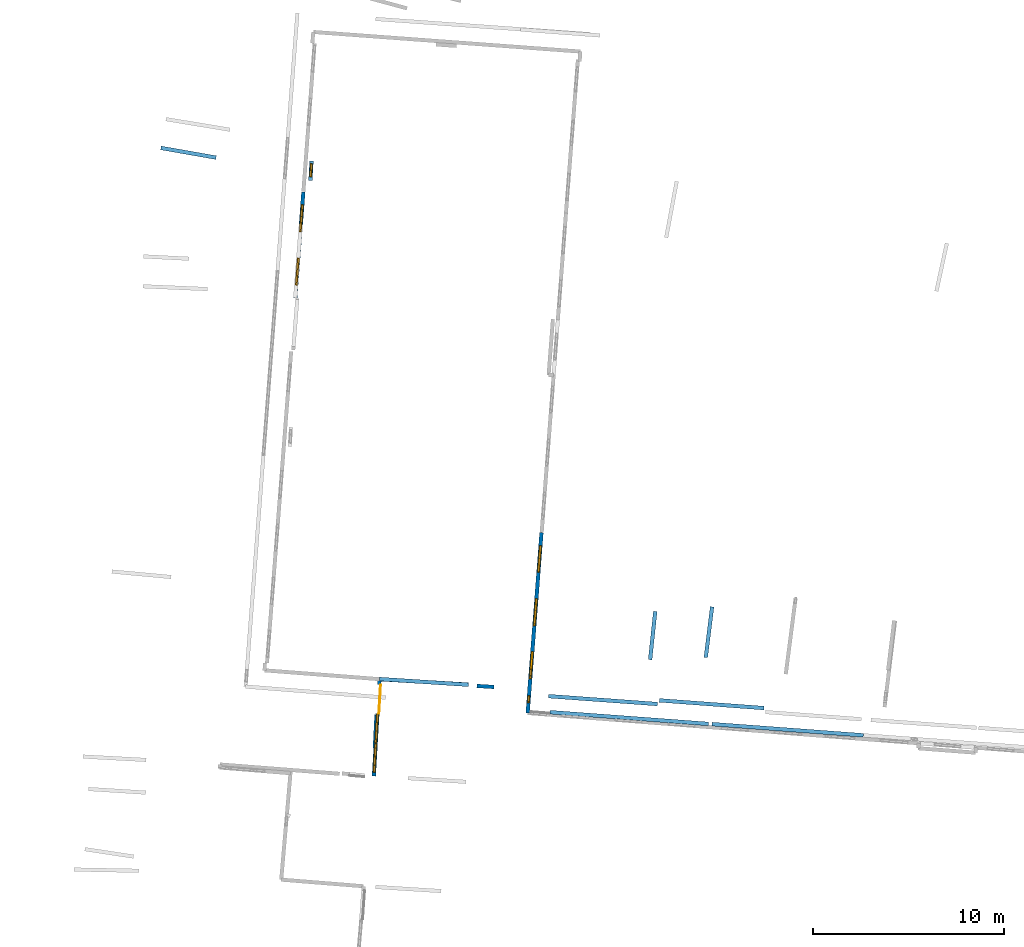
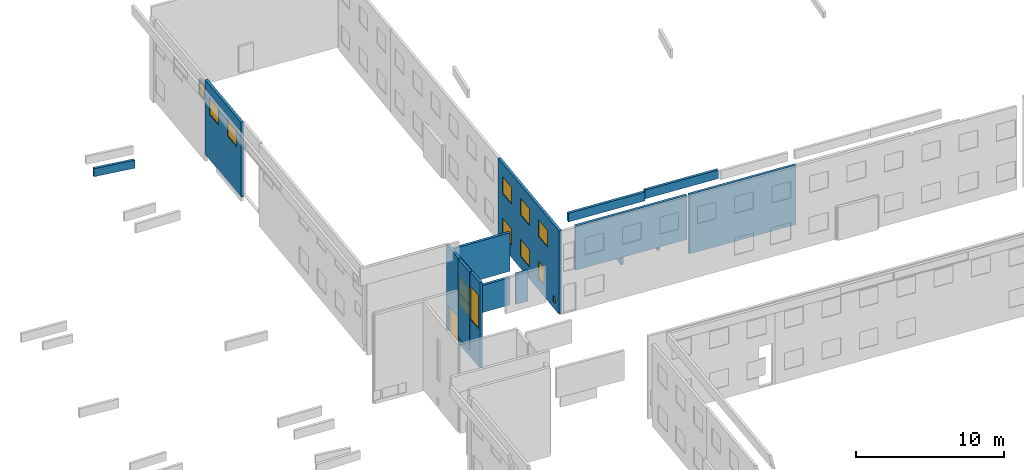
# One storey, part 10 of 27: 15 walls, 13 windows, 1 door, 14 openings.
"""IFC2X3 building model written with IfcOpenShell, lengths in metres."""

from ifc_helpers import new_model, entity, si_unit, converted_unit, derived_unit, direction, frame, frame_2d, origin, origin_2d_with_axis, place, context, subcontext, project, spatial, polyline, rectangle, outline, extrude, source, transform, mapped, material, layer, layer_set, layer_usage, type_object, type_shapes, element, fill, save


model = new_model("IFC2X3")

# Units and contexts
model_context = context("Model", 3, precision=1e-05, world=origin(), true_north=direction((0.0, 1.0)))
body_context = subcontext(model_context, "Body", "Model", "MODEL_VIEW")
ifc_project = project(units=[si_unit("LENGTHUNIT", "METRE"), si_unit("AREAUNIT", "SQUARE_METRE"), si_unit("VOLUMEUNIT", "CUBIC_METRE"), converted_unit("PLANEANGLEUNIT", "DEGREE", entity("IfcRatioMeasure", 0.0174532925199433), si_unit("PLANEANGLEUNIT", "RADIAN"), dimensions=[0, 0, 0, 0, 0, 0, 0]), si_unit("MASSUNIT", "GRAM", prefix="KILO"), derived_unit("MASSDENSITYUNIT", [(si_unit("MASSUNIT", "GRAM", prefix="KILO"), 1), (si_unit("LENGTHUNIT", "METRE"), -3)]), derived_unit("MOMENTOFINERTIAUNIT", [(si_unit("LENGTHUNIT", "METRE"), 4)]), si_unit("TIMEUNIT", "SECOND"), si_unit("FREQUENCYUNIT", "HERTZ"), si_unit("THERMODYNAMICTEMPERATUREUNIT", "DEGREE_CELSIUS"), derived_unit("THERMALTRANSMITTANCEUNIT", [(si_unit("MASSUNIT", "GRAM", prefix="KILO"), 1), (si_unit("THERMODYNAMICTEMPERATUREUNIT", "KELVIN"), -1), (si_unit("TIMEUNIT", "SECOND"), -3)]), derived_unit("VOLUMETRICFLOWRATEUNIT", [(si_unit("LENGTHUNIT", "METRE"), 3), (si_unit("TIMEUNIT", "SECOND"), -1)]), si_unit("ELECTRICCURRENTUNIT", "AMPERE"), si_unit("ELECTRICVOLTAGEUNIT", "VOLT"), si_unit("POWERUNIT", "WATT"), si_unit("FORCEUNIT", "NEWTON", prefix="KILO"), si_unit("ILLUMINANCEUNIT", "LUX"), si_unit("LUMINOUSFLUXUNIT", "LUMEN"), si_unit("LUMINOUSINTENSITYUNIT", "CANDELA"), derived_unit("USERDEFINED", [(si_unit("MASSUNIT", "GRAM", prefix="KILO"), -1), (si_unit("LENGTHUNIT", "METRE"), -2), (si_unit("TIMEUNIT", "SECOND"), 3), (si_unit("LUMINOUSFLUXUNIT", "LUMEN"), 1)]), derived_unit("LINEARVELOCITYUNIT", [(si_unit("LENGTHUNIT", "METRE"), 1), (si_unit("TIMEUNIT", "SECOND"), -1)]), si_unit("PRESSUREUNIT", "PASCAL"), derived_unit("USERDEFINED", [(si_unit("LENGTHUNIT", "METRE"), -2), (si_unit("MASSUNIT", "GRAM", prefix="KILO"), 1), (si_unit("TIMEUNIT", "SECOND"), -2)]), derived_unit("LINEARFORCEUNIT", [(si_unit("MASSUNIT", "GRAM", prefix="KILO"), 1), (si_unit("LENGTHUNIT", "METRE"), 1), (si_unit("TIMEUNIT", "SECOND"), -2), (si_unit("LENGTHUNIT", "METRE"), -1)]), derived_unit("PLANARFORCEUNIT", [(si_unit("MASSUNIT", "GRAM", prefix="KILO"), 1), (si_unit("LENGTHUNIT", "METRE"), 1), (si_unit("TIMEUNIT", "SECOND"), -2), (si_unit("LENGTHUNIT", "METRE"), -2)])], contexts=[model_context])

# Site, building, storey
placement_1 = place(None, origin())
site = spatial("IfcSite", under=ifc_project, at=placement_1, CompositionType="ELEMENT")
building = spatial("IfcBuilding", under=site, at=placement_1, CompositionType="ELEMENT")
storey_placement = place(placement_1, frame((0.0, 0.0, -61.043098449707)))
storey = spatial("IfcBuildingStorey", under=building, at=storey_placement, Name="level_-61.043098", CompositionType="ELEMENT", Elevation=-61.043098449707)

# Walls
ifc_material_1 = material(Name="Default wall")
ifc_layer = layer(ifc_material_1, 0.2)
ifc_layer_set = layer_set([ifc_layer], Name="wall_thickness_0.2000")
ifc_layer_usage = layer_usage(ifc_layer_set, "AXIS2", "POSITIVE", -0.1)
wall_type = type_object("IfcWallType", Name="wall_thickness_0.2000", PredefinedType="STANDARD", material=ifc_layer_set)
placement_2 = place(placement_1, frame((0.0, 0.0, -60.9578857421875)))
wall_1_placement = place(placement_2, frame((-64.112735759703, 3.16203981770517, 0.0), z_axis=(0.0, 0.0, 1.0), x_axis=(0.10589778142317, 0.994377020998399, 0.0)))
element("IfcWallStandardCase", 1, at=wall_1_placement, inside=storey, type_object=wall_type, material=ifc_layer_usage, Name="Wall:412", ObjectType="Wall", context=body_context, shape_type="SweptSolid", body=[
    extrude(outline(polyline([(2.55500015222274, -0.1), (2.55500015222274, 0.1), (0.0, 0.1), (0.0, -0.1), (2.55500015222274, -0.1)])), origin(), (0.0, 0.0, 1.0), 0.739894866943359),
])
placement_3 = place(placement_1, frame((0.0, 0.0, -54.3638687133789)))
wall_2_placement = place(placement_3, frame((-69.4426639568922, 1.2512869218751, 0.0), z_axis=(0.0, 0.0, 1.0), x_axis=(0.997381828722827, -0.0723151971131164, 0.0)))
element("IfcWallStandardCase", 2, at=wall_2_placement, inside=storey, type_object=wall_type, material=ifc_layer_usage, Name="Wall:456", ObjectType="Wall", context=body_context, shape_type="SweptSolid", body=[
    extrude(outline(polyline([(5.72448322198204, -0.1), (5.72448322198204, 0.1), (0.0, 0.1), (0.0, -0.1), (5.72448322198204, -0.1)])), origin(), (0.0, 0.0, 1.0), 0.715465545654297),
])
placement_4 = place(placement_1, frame((0.0, 0.0, -54.3638687133789)))
wall_3_placement = place(placement_4, frame((-63.6283458808543, 1.03027042480105, 0.0), z_axis=(0.0, 0.0, 1.0), x_axis=(0.997280749559417, -0.0736960416725798, 0.0)))
element("IfcWallStandardCase", 3, at=wall_3_placement, inside=storey, type_object=wall_type, material=ifc_layer_usage, Name="Wall:498", ObjectType="Wall", context=body_context, shape_type="SweptSolid", body=[
    extrude(outline(polyline([(5.50999725313202, -0.1), (5.50999725313202, 0.1), (0.0, 0.1), (0.0, -0.1), (5.50999725313202, -0.1)])), origin(), (0.0, 0.0, 1.0), 0.715465545654297),
])

# Wall, opening, window
placement_5 = place(placement_1, frame((0.0, 0.0, -56.5068283081055)))
wall_4_placement = place(placement_5, frame((-81.8839520140504, 29.3355039390393, 0.0), z_axis=(0.0, 0.0, 1.0), x_axis=(-0.055985522658437, -0.998431580656713, 0.0)))
wall_4 = element("IfcWallStandardCase", 4, at=wall_4_placement, inside=storey, type_object=wall_type, material=ifc_layer_usage, Name="Wall:538", ObjectType="Wall", context=body_context, shape_type="SweptSolid", body=[
    extrude(outline(polyline([(1.01865127649209, -0.1), (1.01865127649209, 0.1), (0.0, 0.1), (0.0, -0.1), (1.01865127649209, -0.1)])), origin(), (0.0, 0.0, 1.0), 1.24327087402344),
])
opening_1_placement = place(wall_4_placement, frame((0.130000357016459, -0.1, 0.0713768005371094)))
opening_1 = element("IfcOpeningElement", 5, at=opening_1_placement, cuts=wall_4, Name="Opening : 695 x 1085 : 42", ObjectType="Opening", context=body_context, shape_type="SweptSolid", body=[
    extrude(rectangle(XDim=0.695, YDim=1.085, at=frame_2d((0.5425, 0.3475), x_axis=(0.0, 1.0))), frame((0.0, 0.0, 0.0), z_axis=(0.0, 1.0, 0.0), x_axis=(0.0, 0.0, 1.0)), (0.0, 0.0, 1.0), 0.2),
])
ifc_material_2 = material(Name="Window Default")
window_style_1 = type_object("IfcWindowStyle", Name="Window : 695 x 1085mm", ConstructionType="NOTDEFINED", OperationType="NOTDEFINED", ParameterTakesPrecedence=False, Sizeable=False, material=ifc_material_2)
shared_shape_1 = source(origin(), body_context, "Body", "SweptSolid", [
    extrude(rectangle(XDim=0.1, YDim=0.695, at=origin_2d_with_axis()), frame((0.3475, 0.1, 0.0), z_axis=(0.0, 0.0, 1.0), x_axis=(0.0, 1.0, 0.0)), (0.0, 0.0, 1.0), 1.085),
])
type_shapes(window_style_1, [shared_shape_1])
window_1_placement = place(opening_1_placement, origin())
window_1 = element("IfcWindow", 6, at=window_1_placement, inside=storey, type_object=window_style_1, Name="Window : 695 x 1085mm : 35", ObjectType="Window : 695 x 1085mm", OverallHeight=1.085, OverallWidth=0.695, context=body_context, shape_type="MappedRepresentation", body=[
    mapped(shared_shape_1, transform((0.0, 0.0, 0.0), scale=1.0)),
])
fill(opening_1, window_1)

# Wall, openings, windows
placement_6 = place(placement_1, frame((0.0, 0.0, -60.3636169433594)))
wall_5_placement = place(placement_6, frame((-82.3132261424447, 27.7098663354624, 0.0), z_axis=(0.0, 0.0, 1.0), x_axis=(-0.0754661306189968, -0.997148365655481, 0.0)))
wall_5 = element("IfcWallStandardCase", 7, at=wall_5_placement, inside=storey, type_object=wall_type, material=ifc_layer_usage, Name="Wall:612", ObjectType="Wall", context=body_context, shape_type="SweptSolid", body=[
    extrude(outline(polyline([(5.58499909863244, -0.1), (5.58499909863244, 0.1), (0.0, 0.1), (0.0, -0.1), (5.58499909863244, -0.1)])), origin(), (0.0, 0.0, 1.0), 6.15444183349609),
])
opening_2_placement = place(wall_5_placement, frame((0.669999334969992, -0.1, 3.72430038452148)))
opening_2 = element("IfcOpeningElement", 8, at=opening_2_placement, cuts=wall_5, Name="Opening : 1420 x 1400 : 43", ObjectType="Opening", context=body_context, shape_type="SweptSolid", body=[
    extrude(rectangle(XDim=1.42, YDim=1.4, at=frame_2d((0.7, 0.71), x_axis=(0.0, 1.0))), frame((0.0, 0.0, 0.0), z_axis=(0.0, 1.0, 0.0), x_axis=(0.0, 0.0, 1.0)), (0.0, 0.0, 1.0), 0.2),
])
opening_3_placement = place(wall_5_placement, frame((3.47499925768851, -0.1, 3.71930313110352)))
opening_3 = element("IfcOpeningElement", 9, at=opening_3_placement, cuts=wall_5, Name="Opening : 1420 x 1400 : 44", ObjectType="Opening", context=body_context, shape_type="SweptSolid", body=[
    extrude(rectangle(XDim=1.42, YDim=1.4, at=frame_2d((0.7, 0.71), x_axis=(0.0, 1.0))), frame((0.0, 0.0, 0.0), z_axis=(0.0, 1.0, 0.0), x_axis=(0.0, 0.0, 1.0)), (0.0, 0.0, 1.0), 0.2),
])
window_style_2 = type_object("IfcWindowStyle", Name="Window : 1420 x 1400mm", ConstructionType="NOTDEFINED", OperationType="NOTDEFINED", ParameterTakesPrecedence=False, Sizeable=False, material=ifc_material_2)
shared_shape_2 = source(origin(), body_context, "Body", "SweptSolid", [
    extrude(rectangle(XDim=0.1, YDim=1.42, at=origin_2d_with_axis()), frame((0.71, 0.1, 0.0), z_axis=(0.0, 0.0, 1.0), x_axis=(0.0, 1.0, 0.0)), (0.0, 0.0, 1.0), 1.4),
])
type_shapes(window_style_2, [shared_shape_2])
window_2_placement = place(opening_2_placement, origin())
window_2 = element("IfcWindow", 10, at=window_2_placement, inside=storey, type_object=window_style_2, Name="Window : 1420 x 1400mm : 36", ObjectType="Window : 1420 x 1400mm", OverallHeight=1.4, OverallWidth=1.42, context=body_context, shape_type="MappedRepresentation", body=[
    mapped(shared_shape_2, transform((0.0, 0.0, 0.0), scale=1.0)),
])
fill(opening_2, window_2)
window_3_placement = place(opening_3_placement, origin())
window_3 = element("IfcWindow", 11, at=window_3_placement, inside=storey, type_object=window_style_2, Name="Window : 1420 x 1400mm : 37", ObjectType="Window : 1420 x 1400mm", OverallHeight=1.4, OverallWidth=1.42, context=body_context, shape_type="MappedRepresentation", body=[
    mapped(shared_shape_2, transform((0.0, 0.0, 0.0), scale=1.0)),
])
fill(opening_3, window_3)

# Walls
placement_7 = place(placement_1, frame((0.0, 0.0, -60.1485977172852)))
wall_6_placement = place(placement_7, frame((-73.2067005350484, 1.78836395852035, 0.0), z_axis=(0.0, 0.0, 1.0), x_axis=(0.998058568908712, -0.0622823653042681, 0.0)))
element("IfcWallStandardCase", 12, at=wall_6_placement, inside=storey, type_object=wall_type, material=ifc_layer_usage, Name="Wall:741", ObjectType="Wall", context=body_context, shape_type="SweptSolid", body=[
    extrude(outline(polyline([(0.89999404155096, -0.1), (0.89999404155096, 0.1), (0.0, 0.1), (0.0, -0.1), (0.89999404155096, -0.1)])), origin(), (0.0, 0.0, 1.0), 2.47006988525391),
])
placement_8 = place(placement_1, frame((0.0, 0.0, -60.9578857421875)))
wall_7_placement = place(placement_8, frame((-89.789241164365, 30.0248848683254, 0.0), z_axis=(0.0, 0.0, 1.0), x_axis=(0.984894523482276, -0.173155356875321, 0.0)))
element("IfcWallStandardCase", 13, at=wall_7_placement, inside=storey, type_object=wall_type, material=ifc_layer_usage, Name="Wall:871", ObjectType="Wall", context=body_context, shape_type="SweptSolid", body=[
    extrude(outline(polyline([(2.94000186497326, -0.1), (2.94000186497326, 0.1), (0.0, 0.1), (0.0, -0.1), (2.94000186497326, -0.1)])), origin(), (0.0, 0.0, 1.0), 0.661750793457031),
])

# Wall, openings, door, windows
placement_9 = place(placement_1, frame((0.0, 0.0, -60.6535377502441)))
wall_8_placement = place(placement_9, frame((-78.3148883239851, 2.149042953646, 0.0), z_axis=(0.0, 0.0, 1.0), x_axis=(-0.0582339527093183, -0.998302963409329, 0.0)))
wall_8 = element("IfcWallStandardCase", 14, at=wall_8_placement, inside=storey, type_object=wall_type, material=ifc_layer_usage, Name="Wall:883", ObjectType="Wall", context=body_context, shape_type="SweptSolid", body=[
    extrude(outline(polyline([(5.10543869437025, -0.1), (5.10543869437025, 0.1), (0.0, 0.1), (0.0, -0.1), (5.10543869437025, -0.1)])), origin(), (0.0, 0.0, 1.0), 7.00513458251953),
])
opening_4_placement = place(wall_8_placement, frame((0.291380808125082, -0.1, -0.165592193603516)))
opening_4 = element("IfcOpeningElement", 15, at=opening_4_placement, cuts=wall_8, Name="Opening : 1525 x 2320 : 104", ObjectType="Opening", context=body_context, shape_type="SweptSolid", body=[
    extrude(rectangle(XDim=1.525, YDim=2.32, at=frame_2d((1.16, 0.7625), x_axis=(0.0, 1.0))), frame((0.0, 0.0, 0.0), z_axis=(0.0, 1.0, 0.0), x_axis=(0.0, 0.0, 1.0)), (0.0, 0.0, 1.0), 0.2),
])
opening_5_placement = place(wall_8_placement, frame((3.39348843057479, -0.1, 3.10876846313477)))
opening_5 = element("IfcOpeningElement", 16, at=opening_5_placement, cuts=wall_8, Name="Opening : 1500 x 2735 : 105", ObjectType="Opening", context=body_context, shape_type="SweptSolid", body=[
    extrude(rectangle(XDim=1.5, YDim=2.735, at=frame_2d((1.3675, 0.75), x_axis=(0.0, 1.0))), frame((0.0, 0.0, 0.0), z_axis=(0.0, 1.0, 0.0), x_axis=(0.0, 0.0, 1.0)), (0.0, 0.0, 1.0), 0.2),
])
opening_6_placement = place(wall_8_placement, frame((1.838488199847, -0.1, 4.12876510620117)))
opening_6 = element("IfcOpeningElement", 17, at=opening_6_placement, cuts=wall_8, Name="Opening : 1520 x 1270 : 106", ObjectType="Opening", context=body_context, shape_type="SweptSolid", body=[
    extrude(rectangle(XDim=1.52, YDim=1.27, at=frame_2d((0.635, 0.76), x_axis=(0.0, 1.0))), frame((0.0, 0.0, 0.0), z_axis=(0.0, 1.0, 0.0), x_axis=(0.0, 0.0, 1.0)), (0.0, 0.0, 1.0), 0.2),
])
opening_7_placement = place(wall_8_placement, frame((1.84348802441311, -0.1, 3.16376495361328)))
opening_7 = element("IfcOpeningElement", 18, at=opening_7_placement, cuts=wall_8, Name="Opening : 1510 x 940 : 107", ObjectType="Opening", context=body_context, shape_type="SweptSolid", body=[
    extrude(rectangle(XDim=1.51, YDim=0.94, at=frame_2d((0.47, 0.755), x_axis=(0.0, 1.0))), frame((0.0, 0.0, 0.0), z_axis=(0.0, 1.0, 0.0), x_axis=(0.0, 0.0, 1.0)), (0.0, 0.0, 1.0), 0.2),
])
ifc_material_3 = material(Name="Door Panel")
door_style = type_object("IfcDoorStyle", Name="Door : 1525 x 2320mm", ConstructionType="NOTDEFINED", OperationType="SINGLE_SWING_RIGHT", ParameterTakesPrecedence=False, Sizeable=False, material=ifc_material_3)
shared_shape_3 = source(origin(), body_context, "Body", "SweptSolid", [
    extrude(rectangle(XDim=0.05, YDim=1.525, at=origin_2d_with_axis()), frame((0.7625, 0.175, 0.0), z_axis=(0.0, 0.0, 1.0), x_axis=(0.0, 1.0, 0.0)), (0.0, 0.0, 1.0), 2.32),
])
type_shapes(door_style, [shared_shape_3])
door_placement = place(opening_4_placement, origin())
door = element("IfcDoor", 19, at=door_placement, inside=storey, type_object=door_style, Name="Door : 1525 x 2320mm : 5", ObjectType="Door : 1525 x 2320mm", OverallHeight=2.32, OverallWidth=1.525, context=body_context, shape_type="MappedRepresentation", body=[
    mapped(shared_shape_3, transform((0.0, 0.0, 0.0), scale=1.0)),
])
fill(opening_4, door)
window_style_3 = type_object("IfcWindowStyle", Name="Window : 1500 x 2735mm", ConstructionType="NOTDEFINED", OperationType="NOTDEFINED", ParameterTakesPrecedence=False, Sizeable=False, material=ifc_material_2)
shared_shape_4 = source(origin(), body_context, "Body", "SweptSolid", [
    extrude(rectangle(XDim=0.1, YDim=1.5, at=origin_2d_with_axis()), frame((0.75, 0.1, 0.0), z_axis=(0.0, 0.0, 1.0), x_axis=(0.0, 1.0, 0.0)), (0.0, 0.0, 1.0), 2.735),
])
type_shapes(window_style_3, [shared_shape_4])
window_4_placement = place(opening_5_placement, origin())
window_4 = element("IfcWindow", 20, at=window_4_placement, inside=storey, type_object=window_style_3, Name="Window : 1500 x 2735mm : 93", ObjectType="Window : 1500 x 2735mm", OverallHeight=2.735, OverallWidth=1.5, context=body_context, shape_type="MappedRepresentation", body=[
    mapped(shared_shape_4, transform((0.0, 0.0, 0.0), scale=1.0)),
])
fill(opening_5, window_4)
window_style_4 = type_object("IfcWindowStyle", Name="Window : 1520 x 1270mm", ConstructionType="NOTDEFINED", OperationType="NOTDEFINED", ParameterTakesPrecedence=False, Sizeable=False, material=ifc_material_2)
shared_shape_5 = source(origin(), body_context, "Body", "SweptSolid", [
    extrude(rectangle(XDim=0.1, YDim=1.52, at=origin_2d_with_axis()), frame((0.76, 0.1, 0.0), z_axis=(0.0, 0.0, 1.0), x_axis=(0.0, 1.0, 0.0)), (0.0, 0.0, 1.0), 1.27),
])
type_shapes(window_style_4, [shared_shape_5])
window_5_placement = place(opening_6_placement, origin())
window_5 = element("IfcWindow", 21, at=window_5_placement, inside=storey, type_object=window_style_4, Name="Window : 1520 x 1270mm : 94", ObjectType="Window : 1520 x 1270mm", OverallHeight=1.27, OverallWidth=1.52, context=body_context, shape_type="MappedRepresentation", body=[
    mapped(shared_shape_5, transform((0.0, 0.0, 0.0), scale=1.0)),
])
fill(opening_6, window_5)
window_style_5 = type_object("IfcWindowStyle", Name="Window : 1510 x 940mm", ConstructionType="NOTDEFINED", OperationType="NOTDEFINED", ParameterTakesPrecedence=False, Sizeable=False, material=ifc_material_2)
shared_shape_6 = source(origin(), body_context, "Body", "SweptSolid", [
    extrude(rectangle(XDim=0.1, YDim=1.51, at=origin_2d_with_axis()), frame((0.755, 0.1, 0.0), z_axis=(0.0, 0.0, 1.0), x_axis=(0.0, 1.0, 0.0)), (0.0, 0.0, 1.0), 0.94),
])
type_shapes(window_style_5, [shared_shape_6])
window_6_placement = place(opening_7_placement, origin())
window_6 = element("IfcWindow", 22, at=window_6_placement, inside=storey, type_object=window_style_5, Name="Window : 1510 x 940mm : 95", ObjectType="Window : 1510 x 940mm", OverallHeight=0.94, OverallWidth=1.51, context=body_context, shape_type="MappedRepresentation", body=[
    mapped(shared_shape_6, transform((0.0, 0.0, 0.0), scale=1.0)),
])
fill(opening_7, window_6)

# Walls
placement_10 = place(placement_1, frame((0.0, 0.0, -57.2983665466309)))
wall_9_placement = place(placement_10, frame((-78.3148907887837, 2.14904233960973, 0.0), z_axis=(0.0, 0.0, 1.0), x_axis=(0.997941214034964, -0.0641352736832305, 0.0)))
element("IfcWallStandardCase", 23, at=wall_9_placement, inside=storey, type_object=wall_type, material=ifc_layer_usage, Name="Wall:933", ObjectType="Wall", context=body_context, shape_type="SweptSolid", body=[
    extrude(outline(polyline([(4.68532051058545, -0.1), (4.68532051058545, 0.1), (0.0, 0.1), (0.0, -0.1), (4.68532051058545, -0.1)])), origin(), (0.0, 0.0, 1.0), 3.16524505615234),
])
placement_11 = place(placement_1, frame((0.0, 0.0, -60.0665283203125)))
wall_10_placement = place(placement_11, frame((-78.3154490147353, 2.13968083764436, 0.0), z_axis=(0.0, 0.0, 1.0), x_axis=(0.998184434771892, -0.0602315048717773, 0.0)))
element("IfcWallStandardCase", 24, at=wall_10_placement, inside=storey, type_object=wall_type, material=ifc_layer_usage, Name="Wall:975", ObjectType="Wall", context=body_context, shape_type="SweptSolid", body=[
    extrude(outline(polyline([(4.67793431803172, -0.1), (4.67793431803172, 0.1), (0.0, 0.1), (0.0, -0.1), (4.67793431803172, -0.1)])), origin(), (0.0, 0.0, 1.0), 2.23800277709961),
])
placement_12 = place(placement_1, frame((0.0, 0.0, -60.8847198486328)))
wall_11_placement = place(placement_12, frame((-61.191986018653, 3.28204770240143, 0.0), z_axis=(0.0, 0.0, 1.0), x_axis=(0.124629422392218, 0.992203359737399, 0.0)))
element("IfcWallStandardCase", 25, at=wall_11_placement, inside=storey, type_object=wall_type, material=ifc_layer_usage, Name="Wall:1282", ObjectType="Wall", context=body_context, shape_type="SweptSolid", body=[
    extrude(outline(polyline([(2.67682003386065, -0.1), (2.67682003386065, 0.1), (0.0, 0.1), (0.0, -0.1), (2.67682003386065, -0.1)])), origin(), (0.0, 0.0, 1.0), 0.751243591308594),
])

# Wall, openings, windows
placement_13 = place(placement_1, frame((0.0, 0.0, -61.0783157348633)))
wall_12_placement = place(placement_13, frame((-69.8141687601153, 9.83084501302699, 0.0), z_axis=(0.0, 0.0, 1.0), x_axis=(-0.0765627213518796, -0.997064767053372, 0.0)))
wall_12 = element("IfcWallStandardCase", 26, at=wall_12_placement, inside=storey, type_object=wall_type, material=ifc_layer_usage, Name="Wall:1606", ObjectType="Wall", context=body_context, shape_type="SweptSolid", body=[
    extrude(outline(polyline([(9.49455163168196, -0.1), (9.49455163168196, 0.1), (0.0, 0.1), (0.0, -0.1), (9.49455163168196, -0.1)])), origin(), (0.0, 0.0, 1.0), 6.869140625),
])
opening_8_placement = place(wall_12_placement, frame((8.58987810045361, -0.1, 0.516605377197266)))
opening_8 = element("IfcOpeningElement", 27, at=opening_8_placement, cuts=wall_12, Name="Opening : 365 x 480 : 259", ObjectType="Opening", context=body_context, shape_type="SweptSolid", body=[
    extrude(rectangle(XDim=0.365, YDim=0.48, at=frame_2d((0.24, 0.1825), x_axis=(0.0, 1.0))), frame((0.0, 0.0, 0.0), z_axis=(0.0, 1.0, 0.0), x_axis=(0.0, 0.0, 1.0)), (0.0, 0.0, 1.0), 0.2),
])
opening_9_placement = place(wall_12_placement, frame((0.679999256598194, -0.1, 4.40279769897461)))
opening_9 = element("IfcOpeningElement", 28, at=opening_9_placement, cuts=wall_12, Name="Opening : 1400 x 1375 : 260", ObjectType="Opening", context=body_context, shape_type="SweptSolid", body=[
    extrude(rectangle(XDim=1.4, YDim=1.375, at=frame_2d((0.6875, 0.7), x_axis=(0.0, 1.0))), frame((0.0, 0.0, 0.0), z_axis=(0.0, 1.0, 0.0), x_axis=(0.0, 0.0, 1.0)), (0.0, 0.0, 1.0), 0.2),
])
opening_10_placement = place(wall_12_placement, frame((3.47999906822268, -0.1, 4.40279769897461)))
opening_10 = element("IfcOpeningElement", 29, at=opening_10_placement, cuts=wall_12, Name="Opening : 1420 x 1375 : 261", ObjectType="Opening", context=body_context, shape_type="SweptSolid", body=[
    extrude(rectangle(XDim=1.42, YDim=1.375, at=frame_2d((0.6875, 0.71), x_axis=(0.0, 1.0))), frame((0.0, 0.0, 0.0), z_axis=(0.0, 1.0, 0.0), x_axis=(0.0, 0.0, 1.0)), (0.0, 0.0, 1.0), 0.2),
])
opening_11_placement = place(wall_12_placement, frame((6.26499929166458, -0.1, 4.40279769897461)))
opening_11 = element("IfcOpeningElement", 30, at=opening_11_placement, cuts=wall_12, Name="Opening : 1425 x 1375 : 262", ObjectType="Opening", context=body_context, shape_type="SweptSolid", body=[
    extrude(rectangle(XDim=1.425, YDim=1.375, at=frame_2d((0.6875, 0.7125), x_axis=(0.0, 1.0))), frame((0.0, 0.0, 0.0), z_axis=(0.0, 1.0, 0.0), x_axis=(0.0, 0.0, 1.0)), (0.0, 0.0, 1.0), 0.2),
])
opening_12_placement = place(wall_12_placement, frame((3.47499963792299, -0.1, 0.987796783447266)))
opening_12 = element("IfcOpeningElement", 31, at=opening_12_placement, cuts=wall_12, Name="Opening : 1430 x 1395 : 263", ObjectType="Opening", context=body_context, shape_type="SweptSolid", body=[
    extrude(rectangle(XDim=1.43, YDim=1.395, at=frame_2d((0.6975, 0.715), x_axis=(0.0, 1.0))), frame((0.0, 0.0, 0.0), z_axis=(0.0, 1.0, 0.0), x_axis=(0.0, 0.0, 1.0)), (0.0, 0.0, 1.0), 0.2),
])
opening_13_placement = place(wall_12_placement, frame((6.26499929166458, -0.1, 0.982795715332031)))
opening_13 = element("IfcOpeningElement", 32, at=opening_13_placement, cuts=wall_12, Name="Opening : 920 x 1400 : 264", ObjectType="Opening", context=body_context, shape_type="SweptSolid", body=[
    extrude(rectangle(XDim=0.92, YDim=1.4, at=frame_2d((0.7, 0.46), x_axis=(0.0, 1.0))), frame((0.0, 0.0, 0.0), z_axis=(0.0, 1.0, 0.0), x_axis=(0.0, 0.0, 1.0)), (0.0, 0.0, 1.0), 0.2),
])
opening_14_placement = place(wall_12_placement, frame((0.679999256598194, -0.1, 1.00779724121094)))
opening_14 = element("IfcOpeningElement", 33, at=opening_14_placement, cuts=wall_12, Name="Opening : 1395 x 1365 : 265", ObjectType="Opening", context=body_context, shape_type="SweptSolid", body=[
    extrude(rectangle(XDim=1.395, YDim=1.365, at=frame_2d((0.6825, 0.6975), x_axis=(0.0, 1.0))), frame((0.0, 0.0, 0.0), z_axis=(0.0, 1.0, 0.0), x_axis=(0.0, 0.0, 1.0)), (0.0, 0.0, 1.0), 0.2),
])
window_style_6 = type_object("IfcWindowStyle", Name="Window : 1420 x 1375mm", ConstructionType="NOTDEFINED", OperationType="NOTDEFINED", ParameterTakesPrecedence=False, Sizeable=False, material=ifc_material_2)
shared_shape_7 = source(origin(), body_context, "Body", "SweptSolid", [
    extrude(rectangle(XDim=0.1, YDim=1.42, at=origin_2d_with_axis()), frame((0.71, 0.1, 0.0), z_axis=(0.0, 0.0, 1.0), x_axis=(0.0, 1.0, 0.0)), (0.0, 0.0, 1.0), 1.375),
])
type_shapes(window_style_6, [shared_shape_7])
window_7_placement = place(opening_10_placement, origin())
window_7 = element("IfcWindow", 34, at=window_7_placement, inside=storey, type_object=window_style_6, Name="Window : 1420 x 1375mm : 244", ObjectType="Window : 1420 x 1375mm", OverallHeight=1.375, OverallWidth=1.42, context=body_context, shape_type="MappedRepresentation", body=[
    mapped(shared_shape_7, transform((0.0, 0.0, 0.0), scale=1.0)),
])
fill(opening_10, window_7)
window_style_7 = type_object("IfcWindowStyle", Name="Window : 1400 x 1375mm", ConstructionType="NOTDEFINED", OperationType="NOTDEFINED", ParameterTakesPrecedence=False, Sizeable=False, material=ifc_material_2)
shared_shape_8 = source(origin(), body_context, "Body", "SweptSolid", [
    extrude(rectangle(XDim=0.1, YDim=1.4, at=origin_2d_with_axis()), frame((0.7, 0.1, 0.0), z_axis=(0.0, 0.0, 1.0), x_axis=(0.0, 1.0, 0.0)), (0.0, 0.0, 1.0), 1.375),
])
type_shapes(window_style_7, [shared_shape_8])
window_8_placement = place(opening_9_placement, origin())
window_8 = element("IfcWindow", 35, at=window_8_placement, inside=storey, type_object=window_style_7, Name="Window : 1400 x 1375mm : 243", ObjectType="Window : 1400 x 1375mm", OverallHeight=1.375, OverallWidth=1.4, context=body_context, shape_type="MappedRepresentation", body=[
    mapped(shared_shape_8, transform((0.0, 0.0, 0.0), scale=1.0)),
])
fill(opening_9, window_8)
window_style_8 = type_object("IfcWindowStyle", Name="Window : 1425 x 1375mm", ConstructionType="NOTDEFINED", OperationType="NOTDEFINED", ParameterTakesPrecedence=False, Sizeable=False, material=ifc_material_2)
shared_shape_9 = source(origin(), body_context, "Body", "SweptSolid", [
    extrude(rectangle(XDim=0.1, YDim=1.425, at=origin_2d_with_axis()), frame((0.7125, 0.1, 0.0), z_axis=(0.0, 0.0, 1.0), x_axis=(0.0, 1.0, 0.0)), (0.0, 0.0, 1.0), 1.375),
])
type_shapes(window_style_8, [shared_shape_9])
window_9_placement = place(opening_11_placement, origin())
window_9 = element("IfcWindow", 36, at=window_9_placement, inside=storey, type_object=window_style_8, Name="Window : 1425 x 1375mm : 245", ObjectType="Window : 1425 x 1375mm", OverallHeight=1.375, OverallWidth=1.425, context=body_context, shape_type="MappedRepresentation", body=[
    mapped(shared_shape_9, transform((0.0, 0.0, 0.0), scale=1.0)),
])
fill(opening_11, window_9)
window_style_9 = type_object("IfcWindowStyle", Name="Window : 1430 x 1395mm", ConstructionType="NOTDEFINED", OperationType="NOTDEFINED", ParameterTakesPrecedence=False, Sizeable=False, material=ifc_material_2)
shared_shape_10 = source(origin(), body_context, "Body", "SweptSolid", [
    extrude(rectangle(XDim=0.1, YDim=1.43, at=origin_2d_with_axis()), frame((0.715, 0.1, 0.0), z_axis=(0.0, 0.0, 1.0), x_axis=(0.0, 1.0, 0.0)), (0.0, 0.0, 1.0), 1.395),
])
type_shapes(window_style_9, [shared_shape_10])
window_10_placement = place(opening_12_placement, origin())
window_10 = element("IfcWindow", 37, at=window_10_placement, inside=storey, type_object=window_style_9, Name="Window : 1430 x 1395mm : 246", ObjectType="Window : 1430 x 1395mm", OverallHeight=1.395, OverallWidth=1.43, context=body_context, shape_type="MappedRepresentation", body=[
    mapped(shared_shape_10, transform((0.0, 0.0, 0.0), scale=1.0)),
])
fill(opening_12, window_10)
window_style_10 = type_object("IfcWindowStyle", Name="Window : 365 x 480mm", ConstructionType="NOTDEFINED", OperationType="NOTDEFINED", ParameterTakesPrecedence=False, Sizeable=False, material=ifc_material_2)
shared_shape_11 = source(origin(), body_context, "Body", "SweptSolid", [
    extrude(rectangle(XDim=0.1, YDim=0.365, at=origin_2d_with_axis()), frame((0.1825, 0.1, 0.0), z_axis=(0.0, 0.0, 1.0), x_axis=(0.0, 1.0, 0.0)), (0.0, 0.0, 1.0), 0.48),
])
type_shapes(window_style_10, [shared_shape_11])
window_11_placement = place(opening_8_placement, origin())
window_11 = element("IfcWindow", 38, at=window_11_placement, inside=storey, type_object=window_style_10, Name="Window : 365 x 480mm : 242", ObjectType="Window : 365 x 480mm", OverallHeight=0.48, OverallWidth=0.365, context=body_context, shape_type="MappedRepresentation", body=[
    mapped(shared_shape_11, transform((0.0, 0.0, 0.0), scale=1.0)),
])
fill(opening_8, window_11)
window_style_11 = type_object("IfcWindowStyle", Name="Window : 920 x 1400mm", ConstructionType="NOTDEFINED", OperationType="NOTDEFINED", ParameterTakesPrecedence=False, Sizeable=False, material=ifc_material_2)
shared_shape_12 = source(origin(), body_context, "Body", "SweptSolid", [
    extrude(rectangle(XDim=0.1, YDim=0.92, at=origin_2d_with_axis()), frame((0.46, 0.1, 0.0), z_axis=(0.0, 0.0, 1.0), x_axis=(0.0, 1.0, 0.0)), (0.0, 0.0, 1.0), 1.4),
])
type_shapes(window_style_11, [shared_shape_12])
window_12_placement = place(opening_13_placement, origin())
window_12 = element("IfcWindow", 39, at=window_12_placement, inside=storey, type_object=window_style_11, Name="Window : 920 x 1400mm : 247", ObjectType="Window : 920 x 1400mm", OverallHeight=1.4, OverallWidth=0.92, context=body_context, shape_type="MappedRepresentation", body=[
    mapped(shared_shape_12, transform((0.0, 0.0, 0.0), scale=1.0)),
])
fill(opening_13, window_12)
window_style_12 = type_object("IfcWindowStyle", Name="Window : 1395 x 1365mm", ConstructionType="NOTDEFINED", OperationType="NOTDEFINED", ParameterTakesPrecedence=False, Sizeable=False, material=ifc_material_2)
shared_shape_13 = source(origin(), body_context, "Body", "SweptSolid", [
    extrude(rectangle(XDim=0.1, YDim=1.395, at=origin_2d_with_axis()), frame((0.6975, 0.1, 0.0), z_axis=(0.0, 0.0, 1.0), x_axis=(0.0, 1.0, 0.0)), (0.0, 0.0, 1.0), 1.365),
])
type_shapes(window_style_12, [shared_shape_13])
window_13_placement = place(opening_14_placement, origin())
window_13 = element("IfcWindow", 40, at=window_13_placement, inside=storey, type_object=window_style_12, Name="Window : 1395 x 1365mm : 248", ObjectType="Window : 1395 x 1365mm", OverallHeight=1.365, OverallWidth=1.395, context=body_context, shape_type="MappedRepresentation", body=[
    mapped(shared_shape_13, transform((0.0, 0.0, 0.0), scale=1.0)),
])
fill(opening_14, window_13)

# Walls
placement_14 = place(placement_1, frame((0.0, 0.0, -57.8530082702637)))
wall_13_placement = place(placement_14, frame((-69.3677664987472, 0.410988444455067, 0.0), z_axis=(0.0, 0.0, 1.0), x_axis=(0.99725848099407, -0.073996770776843, 0.0)))
element("IfcWallStandardCase", 41, at=wall_13_placement, inside=storey, type_object=wall_type, material=ifc_layer_usage, Name="Wall:1693", ObjectType="Wall", context=body_context, shape_type="SweptSolid", body=[
    extrude(outline(polyline([(8.33500343287455, -0.1), (8.33500343287455, 0.1), (0.0, 0.1), (0.0, -0.1), (8.33500343287455, -0.1)])), origin(), (0.0, 0.0, 1.0), 3.64383316040039),
])
placement_15 = place(placement_1, frame((0.0, 0.0, -60.0665283203125)))
wall_14_placement = place(placement_15, frame((-78.5644428076402, -1.47165819927014, 0.0), z_axis=(0.0, 0.0, 1.0), x_axis=(0.0506862903514962, 0.998714623889329, 0.0)))
element("IfcWallStandardCase", 42, at=wall_14_placement, inside=storey, type_object=wall_type, material=ifc_layer_usage, Name="Wall:1706", ObjectType="Wall", context=body_context, shape_type="SweptSolid", body=[
    extrude(outline(polyline([(1.74499988433599, -0.1), (1.74499988433599, 0.1), (0.0, 0.1), (0.0, -0.1), (1.74499988433599, -0.1)])), origin(), (0.0, 0.0, 1.0), 6.41812515258789),
])
placement_16 = place(placement_1, frame((0.0, 0.0, -59.1070327758789)))
wall_15_placement = place(placement_16, frame((-60.8731196127173, -0.21619869381479, 0.0), z_axis=(0.0, 0.0, 1.0), x_axis=(0.997274628858484, -0.0737788224030008, 0.0)))
element("IfcWallStandardCase", 43, at=wall_15_placement, inside=storey, type_object=wall_type, material=ifc_layer_usage, Name="Wall:1842", ObjectType="Wall", context=body_context, shape_type="SweptSolid", body=[
    extrude(outline(polyline([(7.96999772156369, -0.1), (7.96999772156369, 0.1), (0.0, 0.1), (0.0, -0.1), (7.96999772156369, -0.1)])), origin(), (0.0, 0.0, 1.0), 4.89785766601562),
])

save(model, "model.ifc")
